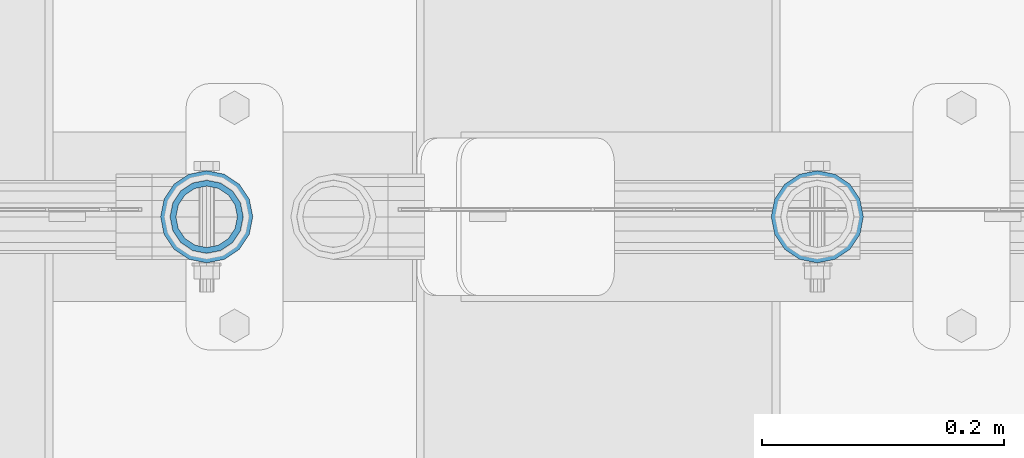
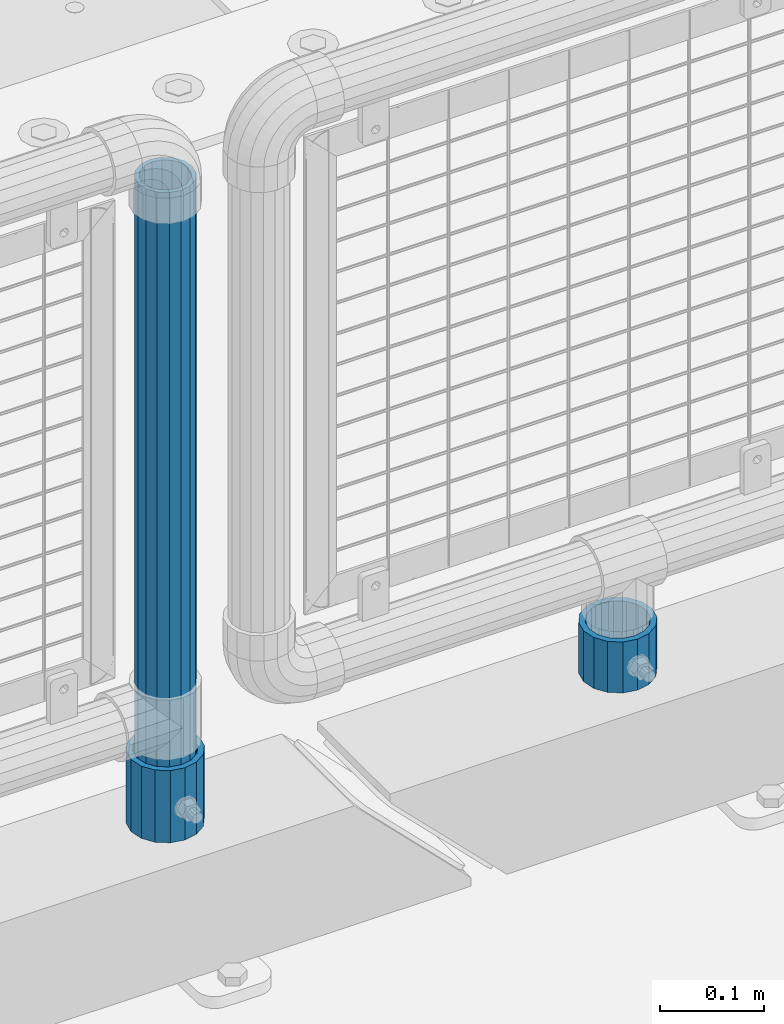
# One storey, part 79 of 193: 3 columns.
"""IFC2X3 building model written with IfcOpenShell, lengths in millimetres."""

import ifcopenshell
import ifcopenshell.guid

model = None  # the IFC model being written
_history = None  # IfcOwnerHistory: only IFC2X3 demands one
_inside = {}  # id of a spatial element -> (the spatial element, [elements in it])
_under = {}  # id of a project, library or spatial element -> (it, [spatial elements below it])
_declared = {}  # id of a project -> (the project, [libraries it declares])
_typed = {}  # id of a type object -> (the type object, [elements of that type])
_made_of = {}  # id of a material, layer set ... -> (it, [elements and type objects made of it])


def new_model(schema):
    """Start an empty IFC model of exactly this schema.

    Asked for "IFC4X3", IfcOpenShell would pick the latest addendum, in which some entities
    have other attributes; the version numbers below select the first issue.
    IFC2X3 requires an IfcOwnerHistory on every rooted entity: one is made here for all.
    """
    global model, _history
    if schema == "IFC4X3":
        model = ifcopenshell.file(schema_version=(4, 3, 0, 0))
    else:
        model = ifcopenshell.file(schema=schema)
    _inside.clear()
    _under.clear()
    _declared.clear()
    _typed.clear()
    _made_of.clear()
    _history = None
    if model.schema == "IFC2X3":
        org = make("IfcOrganization", Name="unknown")
        user = make(
            "IfcPersonAndOrganization",
            ThePerson=make("IfcPerson", FamilyName="unknown"),
            TheOrganization=org,
        )
        app = make(
            "IfcApplication",
            ApplicationDeveloper=org,
            Version="unknown",
            ApplicationFullName="unknown",
            ApplicationIdentifier="unknown",
        )
        _history = make(
            "IfcOwnerHistory",
            OwningUser=user,
            OwningApplication=app,
            ChangeAction="ADDED",
            CreationDate=0,
        )
    return model


def make(cls, **values):
    """One entity of the class cls with the attributes given. An attribute that is None is left unset."""
    return model.create_entity(
        cls, **{name: value for name, value in values.items() if value is not None}
    )


def rooted(cls, **values):
    """An entity with a GlobalId (a new one), such as an element, a storey or a relation."""
    return make(cls, GlobalId=ifcopenshell.guid.new(), OwnerHistory=_history, **values)


def si_unit(unit_type, name, prefix=None):
    """IfcSIUnit, for example si_unit("LENGTHUNIT", "METRE", prefix="MILLI")."""
    return make("IfcSIUnit", UnitType=unit_type, Prefix=prefix, Name=name)


def assignment(units):
    """IfcUnitAssignment: the units of a project."""
    return None if units is None else make("IfcUnitAssignment", Units=units)


def point(xyz):
    """IfcCartesianPoint."""
    return None if xyz is None else make("IfcCartesianPoint", Coordinates=xyz)


def direction(xyz):
    """IfcDirection."""
    return None if xyz is None else make("IfcDirection", DirectionRatios=xyz)


def frame(location, z_axis=None, x_axis=None):
    """IfcAxis2Placement3D, a coordinate frame: its origin and axes. An axis left out is left unset."""
    return make(
        "IfcAxis2Placement3D",
        Location=point(location),
        Axis=direction(z_axis),
        RefDirection=direction(x_axis),
    )


def origin_with_axes():
    """The frame at (0, 0, 0) with the z axis (0, 0, 1) and the x axis (1, 0, 0) written out."""
    return frame((0.0, 0.0, 0.0), z_axis=(0.0, 0.0, 1.0), x_axis=(1.0, 0.0, 0.0))


def place(relative_to, where):
    """IfcLocalPlacement: puts the frame where relative to a parent placement (None: the world)."""
    return make(
        "IfcLocalPlacement", PlacementRelTo=relative_to, RelativePlacement=where
    )


def context(
    kind, dimensions, precision=None, world=None, true_north=None, identifier=None
):
    """IfcGeometricRepresentationContext, for example the 3D "Model" context."""
    return make(
        "IfcGeometricRepresentationContext",
        ContextIdentifier=identifier,
        ContextType=kind,
        CoordinateSpaceDimension=dimensions,
        Precision=precision,
        WorldCoordinateSystem=world,
        TrueNorth=true_north,
    )


def subcontext(parent, identifier, kind, view, scale=None):
    """IfcGeometricRepresentationSubContext, for example "Body" below "Model"."""
    return make(
        "IfcGeometricRepresentationSubContext",
        ContextIdentifier=identifier,
        ContextType=kind,
        ParentContext=parent,
        TargetScale=scale,
        TargetView=view,
    )


def project(units=None, contexts=None):
    """IfcProject with its units and contexts."""
    return rooted(
        "IfcProject",
        Name="project",
        RepresentationContexts=contexts,
        UnitsInContext=assignment(units),
    )


def spatial(cls, under=None, at=None, **own):
    """A site, building, storey or space (cls), placed at a placement, below another one or the project."""
    s = rooted(cls, ObjectPlacement=at, **own)
    if under is not None:
        _under.setdefault(under.id(), (under, []))[1].append(s)
    return s


def faces_of(points, faces, orient=None, outer=None):
    """IfcFace entities. A face is a list of loops; a loop is a list of indices into points, from 0.

    orient and outer hold one flag for each loop. By default every Orientation is true, the
    first loop of a face is its IfcFaceOuterBound and the others are IfcFaceBound.
    """
    made = []
    for i, loops in enumerate(faces):
        bounds = []
        for j, loop in enumerate(loops):
            is_outer = j == 0 if outer is None else outer[i][j]
            bounds.append(
                make(
                    "IfcFaceOuterBound" if is_outer else "IfcFaceBound",
                    Bound=make("IfcPolyLoop", Polygon=[points[k] for k in loop]),
                    Orientation=True if orient is None else orient[i][j],
                )
            )
        made.append(make("IfcFace", Bounds=bounds))
    return made


def faceted_brep(points, faces, orient=None, outer=None, voids=None):
    """IfcFacetedBrep: a solid bounded by flat faces; with voids (closed shells), ...WithVoids."""
    shared = [point(p) for p in points]
    hull = make("IfcClosedShell", CfsFaces=faces_of(shared, faces, orient, outer))
    if voids is None:
        return make("IfcFacetedBrep", Outer=hull)
    return make(
        "IfcFacetedBrepWithVoids",
        Outer=hull,
        Voids=[
            make(cls, CfsFaces=faces_of(shared, fs, o, b)) for cls, fs, o, b in voids
        ],
    )


def shape(context_of_items, identifier, shape_type, items):
    """IfcShapeRepresentation: the items that make up one representation, for example the "Body"."""
    return make(
        "IfcShapeRepresentation",
        ContextOfItems=context_of_items,
        RepresentationIdentifier=identifier,
        RepresentationType=shape_type,
        Items=items,
    )


def material(Name=None, Category=None):
    """IfcMaterial."""
    return make("IfcMaterial", Name=Name, Category=Category)


def made_of(thing, what):
    """Note that an element or type object is made of a material, layer set ...; save() writes the relation."""
    if what is not None:
        _made_of.setdefault(what.id(), (what, []))[1].append(thing)
    return thing


def type_object(cls, material=None, **own):
    """A type object (cls), such as IfcWallType, which elements share."""
    return made_of(rooted(cls, **own), material)


def element(
    cls,
    number,
    at=None,
    inside=None,
    cuts=None,
    type_object=None,
    material=None,
    context=None,
    identifier="Body",
    shape_type=None,
    held_by="IfcProductDefinitionShape",
    body=None,
    shapes=None,
    **own,
):
    """One element of the class cls, such as IfcWall. Its Tag is "e" and its number.

    at: its placement. inside: the storey or other place that contains it. cuts: it is an
    opening in that element (IfcRelVoidsElement). A single representation is given by context,
    identifier, shape_type and body (its items); several are given by shapes. held_by: the class
    of the entity that holds the representations. save() writes the other relations.
    """
    e = rooted(cls, Tag="e%d" % number, ObjectPlacement=at, **own)
    if body is not None:
        shapes = [shape(context, identifier, shape_type, body)]
    if shapes is not None:
        e.Representation = make(held_by, Representations=shapes)
    if inside is not None:
        _inside.setdefault(inside.id(), (inside, []))[1].append(e)
    if cuts is not None:
        rooted(
            "IfcRelVoidsElement", RelatingBuildingElement=cuts, RelatedOpeningElement=e
        )
    if type_object is not None:
        _typed.setdefault(type_object.id(), (type_object, []))[1].append(e)
    return made_of(e, material)


def aggregate(whole, parts):
    """IfcRelAggregates: a whole, such as a stair, and the parts it consists of."""
    return rooted("IfcRelAggregates", RelatingObject=whole, RelatedObjects=parts)


def save(model, path):
    """Write the relations noted so far, then the file.

    IfcRelAggregates (storeys below a building ...), IfcRelContainedInSpatialStructure (elements
    in a storey), IfcRelDefinesByType, IfcRelAssociatesMaterial and IfcRelDeclares: one each for
    every whole, place, type object, material and project.
    """
    for whole, parts in _under.values():
        aggregate(whole, parts)
    for where, things in _inside.values():
        rooted(
            "IfcRelContainedInSpatialStructure",
            RelatedElements=things,
            RelatingStructure=where,
        )
    for kind, things in _typed.values():
        rooted("IfcRelDefinesByType", RelatedObjects=things, RelatingType=kind)
    for what, things in _made_of.values():
        rooted("IfcRelAssociatesMaterial", RelatedObjects=things, RelatingMaterial=what)
    for by, libraries in _declared.values():
        rooted("IfcRelDeclares", RelatingContext=by, RelatedDefinitions=libraries)
    model.write(path)


model = new_model("IFC2X3")

# Units and contexts
model_context = context("Model", 3, precision=1e-05, world=origin_with_axes())
body_context = subcontext(model_context, "Body", "Model", "MODEL_VIEW")
ifc_project = project(units=[si_unit("LENGTHUNIT", "METRE", prefix="MILLI"), si_unit("AREAUNIT", "SQUARE_METRE"), si_unit("VOLUMEUNIT", "CUBIC_METRE"), si_unit("MASSUNIT", "GRAM", prefix="KILO"), si_unit("TIMEUNIT", "SECOND"), si_unit("PLANEANGLEUNIT", "RADIAN"), si_unit("SOLIDANGLEUNIT", "STERADIAN"), si_unit("THERMODYNAMICTEMPERATUREUNIT", "DEGREE_CELSIUS"), si_unit("LUMINOUSINTENSITYUNIT", "LUMEN")], contexts=[model_context])

# Site, building, storey
site_placement = place(None, origin_with_axes())
site = spatial("IfcSite", under=ifc_project, at=site_placement, CompositionType="ELEMENT")
building_placement = place(site_placement, origin_with_axes())
building = spatial("IfcBuilding", under=site, at=building_placement, Name="Standard", CompositionType="ELEMENT")
storey_placement = place(building_placement, origin_with_axes())
storey = spatial("IfcBuildingStorey", under=building, at=storey_placement, Name="Undefined", CompositionType="ELEMENT", Elevation=0.0)

# Columns
ifc_material = material()
column_type_1 = type_object("IfcColumnType", PredefinedType="NOTDEFINED")
column_1_placement = place(storey_placement, frame((-30223.0, 28664.5, 168.02), z_axis=(-1.0, 0.0, 0.0), x_axis=(0.0, 0.0, 1.0)))
element("IfcColumn", 1, at=column_1_placement, inside=storey, type_object=column_type_1, material=ifc_material, context=body_context, shape_type="Brep", body=[
    faceted_brep([(0.0, -25.3499999999985, 0.0), (0.0, -23.4203461491597, 9.70102501045403), (760.0, -23.4203461491597, 9.70102501045403), (760.0, -25.3499999999985, 0.0), (0.0, -17.9251569030785, 17.9251569030785), (760.0, -17.9251569030785, 17.9251569030785), (0.0, -9.70102501045403, 23.4203461491597), (760.0, -9.70102501045403, 23.4203461491597), (0.0, 0.0, 25.3499999999985), (760.0, 0.0, 25.3499999999985), (0.0, 9.70102501045403, 23.4203461491597), (760.0, 9.70102501045403, 23.4203461491597), (0.0, 17.9251569030785, 17.9251569030785), (760.0, 17.9251569030785, 17.9251569030785), (0.0, 23.4203461491597, 9.70102501045403), (760.0, 23.4203461491597, 9.70102501045403), (0.0, 25.3499999999985, 0.0), (760.0, 25.3499999999985, 0.0), (0.0, 23.4203461491597, -9.70102501045403), (760.0, 23.4203461491597, -9.70102501045403), (0.0, 17.9251569030785, -17.9251569030785), (760.0, 17.9251569030785, -17.9251569030785), (0.0, 9.70102501045403, -23.4203461491597), (760.0, 9.70102501045403, -23.4203461491597), (0.0, 0.0, -25.3499999999985), (760.0, 0.0, -25.3499999999985), (0.0, -9.70102501045403, -23.4203461491597), (760.0, -9.70102501045403, -23.4203461491597), (0.0, -17.9251569030785, -17.9251569030785), (760.0, -17.9251569030785, -17.9251569030785), (0.0, -23.4203461491597, -9.70102501045403), (760.0, -23.4203461491597, -9.70102501045403), (0.0, -30.1500000000015, 0.0), (0.0, -27.8549679052157, -11.5379054858058), (760.0, -27.8549679052157, -11.5379054858058), (760.0, -30.1500000000015, 0.0), (0.0, -21.3192694527752, -21.3192694527752), (760.0, -21.3192694527752, -21.3192694527752), (0.0, -11.5379054858058, -27.8549679052157), (760.0, -11.5379054858058, -27.8549679052157), (0.0, 0.0, -30.1500000000015), (760.0, 0.0, -30.1500000000015), (0.0, 11.5379054858058, -27.8549679052157), (760.0, 11.5379054858058, -27.8549679052157), (0.0, 21.3192694527752, -21.3192694527752), (760.0, 21.3192694527752, -21.3192694527752), (0.0, 27.8549679052157, -11.5379054858058), (760.0, 27.8549679052157, -11.5379054858058), (0.0, 30.1500000000015, 0.0), (760.0, 30.1500000000015, 0.0), (0.0, 27.8549679052157, 11.5379054858058), (760.0, 27.8549679052157, 11.5379054858058), (0.0, 21.3192694527752, 21.3192694527752), (760.0, 21.3192694527752, 21.3192694527752), (0.0, 11.5379054858058, 27.8549679052157), (760.0, 11.5379054858058, 27.8549679052157), (0.0, 0.0, 30.1500000000015), (760.0, 0.0, 30.1500000000015), (0.0, -11.5379054858058, 27.8549679052157), (760.0, -11.5379054858058, 27.8549679052157), (0.0, -21.3192694527752, 21.3192694527752), (760.0, -21.3192694527752, 21.3192694527752), (0.0, -27.8549679052157, 11.5379054858058), (760.0, -27.8549679052157, 11.5379054858058)], [[[0, 1, 2, 3]], [[1, 4, 5, 2]], [[4, 6, 7, 5]], [[6, 8, 9, 7]], [[8, 10, 11, 9]], [[10, 12, 13, 11]], [[12, 14, 15, 13]], [[14, 16, 17, 15]], [[16, 18, 19, 17]], [[18, 20, 21, 19]], [[20, 22, 23, 21]], [[22, 24, 25, 23]], [[24, 26, 27, 25]], [[26, 28, 29, 27]], [[28, 30, 31, 29]], [[30, 0, 3, 31]], [[32, 33, 34, 35]], [[33, 36, 37, 34]], [[36, 38, 39, 37]], [[38, 40, 41, 39]], [[40, 42, 43, 41]], [[42, 44, 45, 43]], [[44, 46, 47, 45]], [[46, 48, 49, 47]], [[48, 50, 51, 49]], [[50, 52, 53, 51]], [[52, 54, 55, 53]], [[54, 56, 57, 55]], [[56, 58, 59, 57]], [[58, 60, 61, 59]], [[60, 62, 63, 61]], [[62, 32, 35, 63]], [[37, 39, 41, 43, 45, 47, 49, 51, 53, 55, 57, 59, 61, 63, 35, 34], [5, 7, 9, 11, 13, 15, 17, 19, 21, 23, 25, 27, 29, 31, 3, 2]], [[62, 60, 58, 56, 54, 52, 50, 48, 46, 44, 42, 40, 38, 36, 33, 32], [30, 28, 26, 24, 22, 20, 18, 16, 14, 12, 10, 8, 6, 4, 1, 0]]]),
])
column_type_2 = type_object("IfcColumnType", PredefinedType="NOTDEFINED")
column_2_placement = place(storey_placement, frame((-30223.0, 28664.5, 168.02), z_axis=(0.0, 1.0, 0.0), x_axis=(0.0, 0.0, 1.0)))
element("IfcColumn", 2, at=column_2_placement, inside=storey, type_object=column_type_2, material=ifc_material, context=body_context, shape_type="Brep", body=[
    faceted_brep([(0.0, -31.75, 0.0), (0.0, -29.3331751572332, 12.1501989775934), (85.0, -29.3331751572332, 12.1501989775934), (85.0, -31.75, 0.0), (0.0, -22.4506403026717, 22.4506403026717), (85.0, -22.4506403026717, 22.4506403026717), (0.0, -12.1501989775934, 29.3331751572332), (85.0, -12.1501989775934, 29.3331751572332), (0.0, 0.0, 31.75), (85.0, 0.0, 31.75), (0.0, 12.1501989775934, 29.3331751572332), (85.0, 12.1501989775934, 29.3331751572332), (0.0, 22.4506403026717, 22.4506403026717), (85.0, 22.4506403026717, 22.4506403026717), (0.0, 29.3331751572332, 12.1501989775934), (85.0, 29.3331751572332, 12.1501989775934), (0.0, 31.75, 0.0), (85.0, 31.75, 0.0), (0.0, 29.3331751572332, -12.1501989775934), (85.0, 29.3331751572332, -12.1501989775934), (0.0, 22.4506403026717, -22.4506403026717), (85.0, 22.4506403026717, -22.4506403026717), (0.0, 12.1501989775934, -29.3331751572332), (85.0, 12.1501989775934, -29.3331751572332), (0.0, 0.0, -31.75), (85.0, 0.0, -31.75), (0.0, -12.1501989775934, -29.3331751572332), (85.0, -12.1501989775934, -29.3331751572332), (0.0, -22.4506403026717, -22.4506403026717), (85.0, -22.4506403026717, -22.4506403026717), (0.0, -29.3331751572332, -12.1501989775934), (85.0, -29.3331751572332, -12.1501989775934), (0.0, -38.0499999999993, 0.0), (0.0, -35.1536162120537, -14.5611046014928), (85.0, -35.1536162120537, -14.5611046014928), (85.0, -38.0499999999993, 0.0), (0.0, -26.9054130241493, -26.9054130241493), (85.0, -26.9054130241493, -26.9054130241493), (0.0, -14.5611046014928, -35.1536162120537), (85.0, -14.5611046014928, -35.1536162120537), (0.0, 0.0, -38.0499999999993), (85.0, 0.0, -38.0499999999993), (0.0, 14.5611046014928, -35.1536162120537), (85.0, 14.5611046014928, -35.1536162120537), (0.0, 26.9054130241493, -26.9054130241493), (85.0, 26.9054130241493, -26.9054130241493), (0.0, 35.1536162120537, -14.5611046014928), (85.0, 35.1536162120537, -14.5611046014928), (0.0, 38.0499999999993, 0.0), (85.0, 38.0499999999993, 0.0), (0.0, 35.1536162120537, 14.5611046014928), (85.0, 35.1536162120537, 14.5611046014928), (0.0, 26.9054130241493, 26.9054130241493), (85.0, 26.9054130241493, 26.9054130241493), (0.0, 14.5611046014928, 35.1536162120537), (85.0, 14.5611046014928, 35.1536162120537), (0.0, 0.0, 38.0499999999993), (85.0, 0.0, 38.0499999999993), (0.0, -14.5611046014928, 35.1536162120537), (85.0, -14.5611046014928, 35.1536162120537), (0.0, -26.9054130241493, 26.9054130241493), (85.0, -26.9054130241493, 26.9054130241493), (0.0, -35.1536162120537, 14.5611046014928), (85.0, -35.1536162120537, 14.5611046014928)], [[[0, 1, 2, 3]], [[1, 4, 5, 2]], [[4, 6, 7, 5]], [[6, 8, 9, 7]], [[8, 10, 11, 9]], [[10, 12, 13, 11]], [[12, 14, 15, 13]], [[14, 16, 17, 15]], [[16, 18, 19, 17]], [[18, 20, 21, 19]], [[20, 22, 23, 21]], [[22, 24, 25, 23]], [[24, 26, 27, 25]], [[26, 28, 29, 27]], [[28, 30, 31, 29]], [[30, 0, 3, 31]], [[32, 33, 34, 35]], [[33, 36, 37, 34]], [[36, 38, 39, 37]], [[38, 40, 41, 39]], [[40, 42, 43, 41]], [[42, 44, 45, 43]], [[44, 46, 47, 45]], [[46, 48, 49, 47]], [[48, 50, 51, 49]], [[50, 52, 53, 51]], [[52, 54, 55, 53]], [[54, 56, 57, 55]], [[56, 58, 59, 57]], [[58, 60, 61, 59]], [[60, 62, 63, 61]], [[62, 32, 35, 63]], [[37, 39, 41, 43, 45, 47, 49, 51, 53, 55, 57, 59, 61, 63, 35, 34], [5, 7, 9, 11, 13, 15, 17, 19, 21, 23, 25, 27, 29, 31, 3, 2]], [[62, 60, 58, 56, 54, 52, 50, 48, 46, 44, 42, 40, 38, 36, 33, 32], [30, 28, 26, 24, 22, 20, 18, 16, 14, 12, 10, 8, 6, 4, 1, 0]]]),
])
column_3_placement = place(storey_placement, frame((-29719.0, 28664.5, 168.019999999998), z_axis=(0.0, 1.0, 0.0), x_axis=(0.0, 0.0, 1.0)))
element("IfcColumn", 3, at=column_3_placement, inside=storey, type_object=column_type_2, material=ifc_material, context=body_context, shape_type="Brep", body=[
    faceted_brep([(0.0, -31.75, 0.0), (0.0, -29.3331751572332, 12.1501989775934), (60.0, -29.3331751572332, 12.1501989775934), (60.0, -31.75, 0.0), (0.0, -22.4506403026717, 22.4506403026717), (60.0, -22.4506403026717, 22.4506403026717), (0.0, -12.1501989775934, 29.3331751572332), (60.0, -12.1501989775934, 29.3331751572332), (0.0, 0.0, 31.75), (60.0, 0.0, 31.75), (0.0, 12.1501989775934, 29.3331751572332), (60.0, 12.1501989775934, 29.3331751572332), (0.0, 22.4506403026717, 22.4506403026717), (60.0, 22.4506403026717, 22.4506403026717), (0.0, 29.3331751572332, 12.1501989775934), (60.0, 29.3331751572332, 12.1501989775934), (0.0, 31.75, 0.0), (60.0, 31.75, 0.0), (0.0, 29.3331751572332, -12.1501989775934), (60.0, 29.3331751572332, -12.1501989775934), (0.0, 22.4506403026717, -22.4506403026717), (60.0, 22.4506403026717, -22.4506403026717), (0.0, 12.1501989775934, -29.3331751572332), (60.0, 12.1501989775934, -29.3331751572332), (0.0, 0.0, -31.75), (60.0, 0.0, -31.75), (0.0, -12.1501989775934, -29.3331751572332), (60.0, -12.1501989775934, -29.3331751572332), (0.0, -22.4506403026717, -22.4506403026717), (60.0, -22.4506403026717, -22.4506403026717), (0.0, -29.3331751572332, -12.1501989775934), (60.0, -29.3331751572332, -12.1501989775934), (0.0, -38.0499999999993, 0.0), (0.0, -35.1536162120537, -14.5611046014928), (60.0, -35.1536162120537, -14.5611046014928), (60.0, -38.0499999999993, 0.0), (0.0, -26.9054130241493, -26.9054130241493), (60.0, -26.9054130241493, -26.9054130241493), (0.0, -14.5611046014928, -35.1536162120537), (60.0, -14.5611046014928, -35.1536162120537), (0.0, 0.0, -38.0499999999993), (60.0, 0.0, -38.0499999999993), (0.0, 14.5611046014928, -35.1536162120537), (60.0, 14.5611046014928, -35.1536162120537), (0.0, 26.9054130241493, -26.9054130241493), (60.0, 26.9054130241493, -26.9054130241493), (0.0, 35.1536162120537, -14.5611046014928), (60.0, 35.1536162120537, -14.5611046014928), (0.0, 38.0499999999993, 0.0), (60.0, 38.0499999999993, 0.0), (0.0, 35.1536162120537, 14.5611046014928), (60.0, 35.1536162120537, 14.5611046014928), (0.0, 26.9054130241493, 26.9054130241493), (60.0, 26.9054130241493, 26.9054130241493), (0.0, 14.5611046014928, 35.1536162120537), (60.0, 14.5611046014928, 35.1536162120537), (0.0, 0.0, 38.0499999999993), (60.0, 0.0, 38.0499999999993), (0.0, -14.5611046014928, 35.1536162120537), (60.0, -14.5611046014928, 35.1536162120537), (0.0, -26.9054130241493, 26.9054130241493), (60.0, -26.9054130241493, 26.9054130241493), (0.0, -35.1536162120537, 14.5611046014928), (60.0, -35.1536162120537, 14.5611046014928)], [[[0, 1, 2, 3]], [[1, 4, 5, 2]], [[4, 6, 7, 5]], [[6, 8, 9, 7]], [[8, 10, 11, 9]], [[10, 12, 13, 11]], [[12, 14, 15, 13]], [[14, 16, 17, 15]], [[16, 18, 19, 17]], [[18, 20, 21, 19]], [[20, 22, 23, 21]], [[22, 24, 25, 23]], [[24, 26, 27, 25]], [[26, 28, 29, 27]], [[28, 30, 31, 29]], [[30, 0, 3, 31]], [[32, 33, 34, 35]], [[33, 36, 37, 34]], [[36, 38, 39, 37]], [[38, 40, 41, 39]], [[40, 42, 43, 41]], [[42, 44, 45, 43]], [[44, 46, 47, 45]], [[46, 48, 49, 47]], [[48, 50, 51, 49]], [[50, 52, 53, 51]], [[52, 54, 55, 53]], [[54, 56, 57, 55]], [[56, 58, 59, 57]], [[58, 60, 61, 59]], [[60, 62, 63, 61]], [[62, 32, 35, 63]], [[37, 39, 41, 43, 45, 47, 49, 51, 53, 55, 57, 59, 61, 63, 35, 34], [5, 7, 9, 11, 13, 15, 17, 19, 21, 23, 25, 27, 29, 31, 3, 2]], [[62, 60, 58, 56, 54, 52, 50, 48, 46, 44, 42, 40, 38, 36, 33, 32], [30, 28, 26, 24, 22, 20, 18, 16, 14, 12, 10, 8, 6, 4, 1, 0]]]),
])

save(model, "model.ifc")
